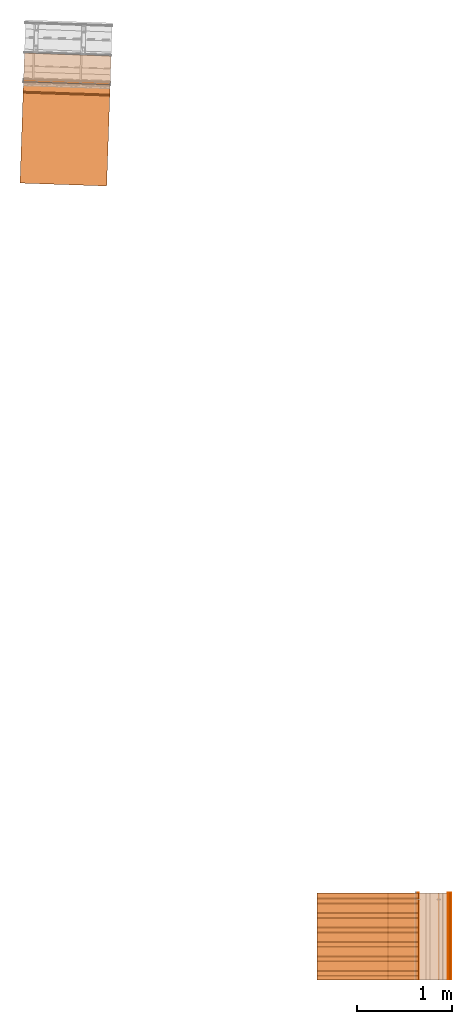
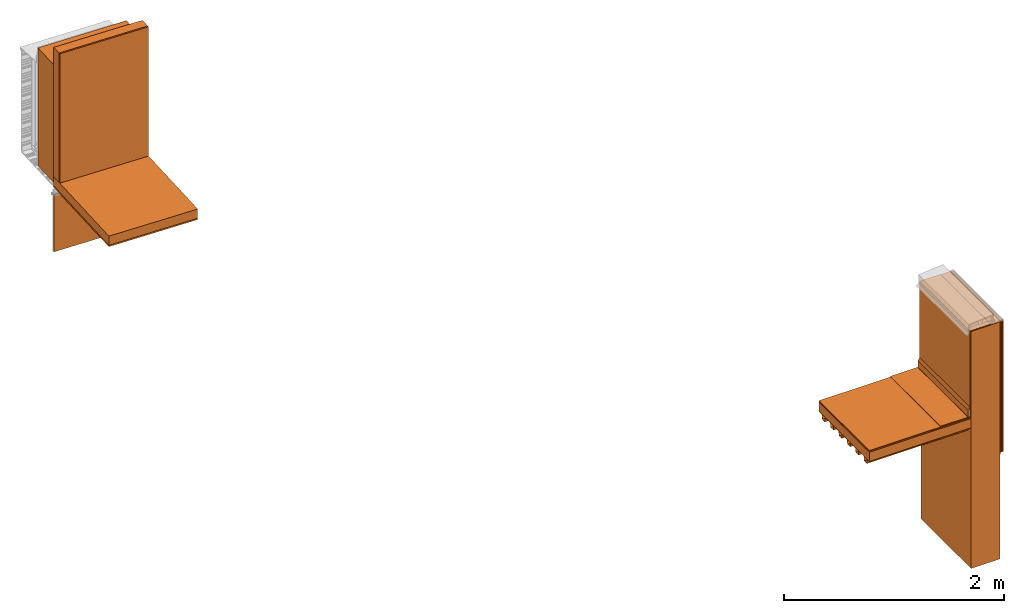
# One storey, part 1 of 7: 19 proxies.
"""IFC2X3 building model written with IfcOpenShell, lengths in feet."""

from ifc_helpers import new_model, entity, si_unit, converted_unit, derived_unit, direction, frame, frame_2d, origin, origin_2d_with_axis, place, context, subcontext, project, spatial, polyline, circle_curve, parameter, trimmed, segment, composite_curve, rectangle, outline, extrude, source, transform, mapped, material, type_object, type_shapes, element, save


model = new_model("IFC2X3")

# Units and contexts
model_context = context("Model", 3, precision=0.0001, world=origin(), true_north=direction((6.12303176911189e-17, 1.0)))
context_of_model = context(None, 3, precision=0.0001, world=origin(), true_north=direction((6.12303176911189e-17, 1.0)))
body_context = subcontext(model_context, "Body", "Model", "MODEL_VIEW")
ifc_project = project(units=[converted_unit("LENGTHUNIT", "FOOT", entity("IfcRatioMeasure", 0.3048), si_unit("LENGTHUNIT", "METRE"), dimensions=[1, 0, 0, 0, 0, 0, 0]), converted_unit("AREAUNIT", "SQUARE FOOT", entity("IfcRatioMeasure", 0.09290304), si_unit("AREAUNIT", "SQUARE_METRE"), dimensions=[2, 0, 0, 0, 0, 0, 0]), converted_unit("VOLUMEUNIT", "CUBIC FOOT", entity("IfcRatioMeasure", 0.028316846592), si_unit("VOLUMEUNIT", "CUBIC_METRE"), dimensions=[3, 0, 0, 0, 0, 0, 0]), converted_unit("PLANEANGLEUNIT", "DEGREE", entity("IfcRatioMeasure", 0.0174532925199433), si_unit("PLANEANGLEUNIT", "RADIAN"), dimensions=[0, 0, 0, 0, 0, 0, 0]), si_unit("MASSUNIT", "GRAM", prefix="KILO"), derived_unit("MASSDENSITYUNIT", [(si_unit("MASSUNIT", "GRAM", prefix="KILO"), 1), (si_unit("LENGTHUNIT", "METRE"), -3)]), si_unit("TIMEUNIT", "SECOND"), si_unit("FREQUENCYUNIT", "HERTZ"), si_unit("THERMODYNAMICTEMPERATUREUNIT", "DEGREE_CELSIUS"), derived_unit("THERMALTRANSMITTANCEUNIT", [(si_unit("MASSUNIT", "GRAM", prefix="KILO"), 1), (si_unit("THERMODYNAMICTEMPERATUREUNIT", "KELVIN"), -1), (si_unit("TIMEUNIT", "SECOND"), -3)]), derived_unit("VOLUMETRICFLOWRATEUNIT", [(si_unit("LENGTHUNIT", "METRE"), 3), (si_unit("TIMEUNIT", "SECOND"), -1)]), si_unit("ELECTRICCURRENTUNIT", "AMPERE"), si_unit("ELECTRICVOLTAGEUNIT", "VOLT"), si_unit("POWERUNIT", "WATT"), si_unit("FORCEUNIT", "NEWTON"), si_unit("ILLUMINANCEUNIT", "LUX"), si_unit("LUMINOUSFLUXUNIT", "LUMEN"), si_unit("LUMINOUSINTENSITYUNIT", "CANDELA"), derived_unit("USERDEFINED", [(si_unit("MASSUNIT", "GRAM", prefix="KILO"), -1), (si_unit("LENGTHUNIT", "METRE"), -2), (si_unit("TIMEUNIT", "SECOND"), 3), (si_unit("LUMINOUSFLUXUNIT", "LUMEN"), 1)]), derived_unit("LINEARVELOCITYUNIT", [(si_unit("LENGTHUNIT", "METRE"), 1), (si_unit("TIMEUNIT", "SECOND"), -1)]), si_unit("PRESSUREUNIT", "PASCAL"), derived_unit("USERDEFINED", [(si_unit("LENGTHUNIT", "METRE"), -2), (si_unit("MASSUNIT", "GRAM", prefix="KILO"), 1), (si_unit("TIMEUNIT", "SECOND"), -2)])], contexts=[model_context, context_of_model])

# Site, building, storey
site_placement = place(None, origin())
site = spatial("IfcSite", under=ifc_project, at=site_placement, CompositionType="ELEMENT")
building_placement = place(site_placement, origin())
building = spatial("IfcBuilding", under=site, at=building_placement, CompositionType="ELEMENT")
storey_placement = place(building_placement, origin())
storey = spatial("IfcBuildingStorey", under=building, at=storey_placement, Name="Level 1", CompositionType="ELEMENT", Elevation=0.0)

# Proxies
ifc_material_1 = material()
building_element_proxy_type_1 = type_object("IfcBuildingElementProxyType", Name="Rigid insulation 002:Rigid insulation 002", PredefinedType="NOTDEFINED", material=ifc_material_1)
shared_shape_1 = source(origin(), body_context, "Body", "SweptSolid", [
    extrude(rectangle(XDim=3.50495130620078, YDim=2.99999999999999, at=frame_2d((0.0, 7.105427357601e-15), x_axis=(1.0, 0.0))), frame((121.624397761532, -80.1652000961286, 15.0), z_axis=(0.0, 0.0, 1.0), x_axis=(-1.0, 0.0, 0.0)), (0.0, 0.0, 1.0), 0.333333333333337),
])
type_shapes(building_element_proxy_type_1, [shared_shape_1])
proxy_1_placement = place(storey_placement, origin())
element("IfcBuildingElementProxy", 1, at=proxy_1_placement, inside=storey, type_object=building_element_proxy_type_1, material=ifc_material_1, context=body_context, shape_type="MappedRepresentation", body=[
    mapped(shared_shape_1, transform((0.0, 0.0, 0.0), scale=1.0)),
])
ifc_material_2 = material(Name="_EXISTING CAST-IN-PLACE CONCRETE")
building_element_proxy_type_2 = type_object("IfcBuildingElementProxyType", Name="Concrete wall 002:Concrete wall 002", PredefinedType="NOTDEFINED", material=ifc_material_2)
shared_shape_2 = source(origin(), body_context, "Body", "SweptSolid", [
    extrude(rectangle(XDim=0.999999999999972, YDim=2.99999999999999, at=frame_2d((1.4210854715202e-14, 7.105427357601e-15), x_axis=(1.0, 0.0))), frame((123.876873414633, -80.1652000961286, 9.875), z_axis=(0.0, 0.0, 1.0), x_axis=(-1.0, 0.0, 0.0)), (0.0, 0.0, 1.0), 8.625),
])
type_shapes(building_element_proxy_type_2, [shared_shape_2])
proxy_2_placement = place(storey_placement, origin())
element("IfcBuildingElementProxy", 2, at=proxy_2_placement, inside=storey, type_object=building_element_proxy_type_2, material=ifc_material_2, ObjectType="Concrete wall 002 : Concrete wall 002:Concrete wall 002", context=body_context, shape_type="MappedRepresentation", body=[
    mapped(shared_shape_2, transform((0.0, 0.0, 0.0), scale=1.0)),
])
ifc_material_3 = material(Name="TPO MEMBRANE ROOF MEMBRANE")
building_element_proxy_type_3 = type_object("IfcBuildingElementProxyType", Name="TPO Membrane 002:TPO Membrane 002", PredefinedType="NOTDEFINED", material=ifc_material_3)
shared_shape_3 = source(origin(), body_context, "Body", "SweptSolid", [
    extrude(outline(composite_curve([segment(polyline([(0.0658482143068539, -2.14143887680021), (0.784598214306726, -2.14143887680021)]), True, "CONTINUOUS"), segment(polyline([(0.784598214306726, -2.14143887680021), (0.784598214306726, -2.13102221013354)]), True, "CONTINUOUS"), segment(polyline([(0.784598214306726, -2.13102221013354), (0.0762648809735396, -2.13102221013354)]), True, "CONTINUOUS"), segment(polyline([(0.0762648809735396, -2.13102221013354), (0.0762648809435831, 0.630175331836318)]), True, "CONTINUOUS"), segment(polyline([(0.0762648809435831, 0.630175331836318), (0.0163690476108229, 0.733917958330316)]), True, "CONTINUOUS"), segment(polyline([(0.0163690476108229, 0.733917958330316), (0.0163690476108229, 0.959969644729439)]), True, "CONTINUOUS"), segment(trimmed(circle_curve(frame_2d((-0.00446428572251989, 0.959969644729439), x_axis=(1.0, 0.0)), 0.0208333333333333), [parameter(0.0)], [parameter(90.0000000000001)], True, "PARAMETER"), True, "CONTINUOUS"), segment(polyline([(-0.00446428572251989, 0.980802978062773), (-0.944568452389419, 0.980802978062776)]), True, "CONTINUOUS"), segment(polyline([(-0.944568452389419, 0.980802978062776), (-0.944568452389419, 0.97038631139611)]), True, "CONTINUOUS"), segment(polyline([(-0.944568452389419, 0.97038631139611), (-0.00446428572251989, 0.970386311396105)]), True, "CONTINUOUS"), segment(trimmed(circle_curve(frame_2d((-0.00446428572251989, 0.959969644729439), x_axis=(1.0, 0.0)), 0.0104166666666667), [parameter(0.0)], [parameter(90.0000000000001)], True, "PARAMETER"), False, "CONTINUOUS"), segment(polyline([(0.00595238094415151, 0.959969644729439), (0.00595238094415151, 0.731126820909159)]), True, "CONTINUOUS"), segment(polyline([(0.00595238094415151, 0.731126820909159), (0.0658482142769685, 0.627384194415056)]), True, "CONTINUOUS"), segment(polyline([(0.0658482142769685, 0.627384194415056), (0.0658482143068539, -2.14143887680021)]), True, "CONTINUOUS")], self_intersect=False)), frame((123.269358533659, -81.6652000961286, 16.3898111231998), z_axis=(0.0, 1.0, 0.0), x_axis=(1.0, 0.0, 0.0)), (0.0, 0.0, 1.0), 3.0),
])
type_shapes(building_element_proxy_type_3, [shared_shape_3])
proxy_3_placement = place(storey_placement, origin())
element("IfcBuildingElementProxy", 3, at=proxy_3_placement, inside=storey, type_object=building_element_proxy_type_3, material=ifc_material_3, ObjectType="TPO Membrane 002 : TPO Membrane 002:TPO Membrane 002", context=body_context, shape_type="MappedRepresentation", body=[
    mapped(shared_shape_3, transform((0.0, 0.0, 0.0), scale=1.0)),
])
ifc_material_4 = material()
building_element_proxy_type_4 = type_object("IfcBuildingElementProxyType", Name="Mortar bed 1:Mortar bed 002", PredefinedType="NOTDEFINED", material=ifc_material_4)
shared_shape_4 = source(origin(), body_context, "Body", "SweptSolid", [
    extrude(rectangle(XDim=3.0, YDim=0.0208333333333712, at=origin_2d_with_axis()), frame((123.366456747966, -80.1652000961286, 15.375), z_axis=(0.0, 0.0, 1.0), x_axis=(0.0, 1.0, 0.0)), (0.0, 0.0, 1.0), 3.125),
])
type_shapes(building_element_proxy_type_4, [shared_shape_4])
proxy_4_placement = place(storey_placement, origin())
element("IfcBuildingElementProxy", 4, at=proxy_4_placement, inside=storey, type_object=building_element_proxy_type_4, material=ifc_material_4, ObjectType="Mortar bed 002 : Mortar bed 1:Mortar bed 002", context=body_context, shape_type="MappedRepresentation", body=[
    mapped(shared_shape_4, transform((0.0, 0.0, 0.0), scale=1.0)),
])
ifc_material_5 = material(Name="PRESSURE TREATED WOOD BLOCKING - SIZE AS")
building_element_proxy_type_5 = type_object("IfcBuildingElementProxyType", Name="Concrete wall001", PredefinedType="NOTDEFINED", material=ifc_material_5)
shared_shape_5 = source(origin(), body_context, "Body", "SweptSolid", [
    extrude(rectangle(XDim=3.0, YDim=1.00000000008858, at=origin_2d_with_axis()), frame((111.232112399029, -50.1693051540586, 9.87499999999999), z_axis=(0.0, 0.0, 1.0), x_axis=(-0.999414947916633, 0.034201781836541, 0.0)), (0.0, 0.0, 1.0), 4.29166666666666),
])
type_shapes(building_element_proxy_type_5, [shared_shape_5])
proxy_5_placement = place(storey_placement, origin())
element("IfcBuildingElementProxy", 5, at=proxy_5_placement, inside=storey, type_object=building_element_proxy_type_5, material=ifc_material_5, Name="Concrete wall001:Concrete wall001", ObjectType="Concrete wall001", context=body_context, shape_type="MappedRepresentation", body=[
    mapped(shared_shape_5, transform((0.0, 0.0, 0.0), scale=1.0)),
])
ifc_material_6 = material(Name="Rigid insulation")
building_element_proxy_type_6 = type_object("IfcBuildingElementProxyType", Name="Insulation horizontal001", PredefinedType="NOTDEFINED", material=ifc_material_6)
shared_shape_6 = source(origin(), body_context, "Body", "SweptSolid", [
    extrude(rectangle(XDim=3.00000000000001, YDim=3.50495130610237, at=frame_2d((7.105427357601e-15, 2.22044604925031e-16), x_axis=(1.0, 0.0))), frame((111.15507371815, -52.4204629915805, 9.76041666666666), z_axis=(0.0, 0.0, 1.0), x_axis=(-0.999414947916632, 0.0342017818365576, 0.0)), (0.0, 0.0, 1.0), 0.333333333333334),
])
type_shapes(building_element_proxy_type_6, [shared_shape_6])
proxy_6_placement = place(storey_placement, origin())
element("IfcBuildingElementProxy", 6, at=proxy_6_placement, inside=storey, type_object=building_element_proxy_type_6, material=ifc_material_6, Name="Insulation horizontal001:Insulation horizontal001", ObjectType="Insulation horizontal001", context=body_context, shape_type="MappedRepresentation", body=[
    mapped(shared_shape_6, transform((0.0, 0.0, 0.0), scale=1.0)),
])
building_element_proxy_type_7 = type_object("IfcBuildingElementProxyType", Name="Insulation vertical001", PredefinedType="NOTDEFINED", material=ifc_material_6)
shared_shape_7 = source(origin(), body_context, "Body", "SweptSolid", [
    extrude(rectangle(XDim=2.99999999999999, YDim=0.333333333431769, at=frame_2d((7.105427357601e-15, 2.35922392732846e-16), x_axis=(1.0, 0.0))), frame((111.209311211139, -50.8355817859981, 10.09375), z_axis=(0.0, 0.0, 1.0), x_axis=(-0.999414947916632, 0.0342017818365767, 0.0)), (0.0, 0.0, 1.0), 4.7067749343832),
])
type_shapes(building_element_proxy_type_7, [shared_shape_7])
proxy_7_placement = place(storey_placement, origin())
element("IfcBuildingElementProxy", 7, at=proxy_7_placement, inside=storey, type_object=building_element_proxy_type_7, material=ifc_material_6, Name="Insulation vertical001:Insulation vertical001", ObjectType="Insulation vertical001", context=body_context, shape_type="MappedRepresentation", body=[
    mapped(shared_shape_7, transform((0.0, 0.0, 0.0), scale=1.0)),
])
building_element_proxy_type_8 = type_object("IfcBuildingElementProxyType", Name="Inner gypsum board001", PredefinedType="NOTDEFINED", material=ifc_material_5)
shared_shape_8 = source(origin(), body_context, "Body", "SweptSolid", [
    extrude(rectangle(XDim=3.00000000000001, YDim=0.0520833333333173, at=frame_2d((1.11022302462516e-16, -3.55097895532452e-15), x_axis=(1.0, 0.0))), frame((111.202720242762, -51.0281773749685, 10.09375), z_axis=(0.0, 0.0, 1.0), x_axis=(-0.999414947916637, 0.0342017818364297, 0.0)), (0.0, 0.0, 1.0), 4.7067749343832),
])
type_shapes(building_element_proxy_type_8, [shared_shape_8])
proxy_8_placement = place(storey_placement, origin())
element("IfcBuildingElementProxy", 8, at=proxy_8_placement, inside=storey, type_object=building_element_proxy_type_8, material=ifc_material_5, Name="Inner gypsum board001:Inner gypsum board001", ObjectType="Inner gypsum board001", context=body_context, shape_type="MappedRepresentation", body=[
    mapped(shared_shape_8, transform((0.0, 0.0, 0.0), scale=1.0)),
])
building_element_proxy_type_9 = type_object("IfcBuildingElementProxyType", Name="Inner ceiling001", PredefinedType="NOTDEFINED", material=ifc_material_5)
shared_shape_9 = source(origin(), body_context, "Body", "SweptSolid", [
    extrude(rectangle(XDim=3.0, YDim=3.50495130633201, at=frame_2d((7.105427357601e-15, 2.22044604925031e-16), x_axis=(1.0, 0.0))), frame((111.155073718154, -52.4204629914657, 9.70833333333332), z_axis=(0.0, 0.0, 1.0), x_axis=(-0.999414947916632, 0.0342017818365529, 0.0)), (0.0, 0.0, 1.0), 0.0520833333333339),
])
type_shapes(building_element_proxy_type_9, [shared_shape_9])
proxy_9_placement = place(storey_placement, origin())
element("IfcBuildingElementProxy", 9, at=proxy_9_placement, inside=storey, type_object=building_element_proxy_type_9, material=ifc_material_5, Name="Inner ceiling001:Inner ceiling001", ObjectType="Inner ceiling001", context=body_context, shape_type="MappedRepresentation", body=[
    mapped(shared_shape_9, transform((0.0, 0.0, 0.0), scale=1.0)),
])
ifc_material_7 = material(Name="Clear glass")
building_element_proxy_type_10 = type_object("IfcBuildingElementProxyType", Name="Glass panel 004", PredefinedType="NOTDEFINED", material=ifc_material_7)
shared_shape_10 = source(origin(), body_context, "Body", "SweptSolid", [
    extrude(rectangle(XDim=3.0, YDim=0.0156250000000211, at=origin_2d_with_axis()), frame((111.2150071805, -50.6691390856077, 7.3556443373819), z_axis=(0.0, 0.0, 1.0), x_axis=(-0.999414947916663, 0.0342017818356435, 0.0)), (0.0, 0.0, 1.0), 2.094323495),
])
type_shapes(building_element_proxy_type_10, [shared_shape_10])
proxy_10_placement = place(storey_placement, origin())
element("IfcBuildingElementProxy", 10, at=proxy_10_placement, inside=storey, type_object=building_element_proxy_type_10, material=ifc_material_7, Name="Glass panel 004:Glass panel 004", ObjectType="Glass panel 004", context=body_context, shape_type="MappedRepresentation", body=[
    mapped(shared_shape_10, transform((0.0, 0.0, 0.0), scale=1.0)),
])
ifc_material_8 = material()
building_element_proxy_type_11 = type_object("IfcBuildingElementProxyType", Name="Cement bond coat 002:Cement bond coat 002", PredefinedType="NOTDEFINED", material=ifc_material_8)
shared_shape_11 = source(origin(), body_context, "Body", "SweptSolid", [
    extrude(outline(polyline([(-2.88843881966443, 0.15882808898568), (-2.88843881966443, -0.648697504397737), (-2.88323048633111, -0.648697504397737), (-2.8832304863311, 0.153619755652366), (1.89789785805362, 0.153619755652366), (1.91489411546504, 0.165520663213195), (1.96051951366896, 0.165520663213195), (1.96051951366896, 0.170728996546524), (1.91325193427296, 0.170728996546524), (1.89625567686151, 0.158828088985681), (-2.88843881966443, 0.15882808898568)])), frame((124.223253658968, -81.6652000961286, 15.6271861803356), z_axis=(0.0, -1.0, 0.0), x_axis=(0.0, 0.0, -1.0)), (0.0, 0.0, -1.0), 3.0),
])
type_shapes(building_element_proxy_type_11, [shared_shape_11])
proxy_11_placement = place(storey_placement, origin())
element("IfcBuildingElementProxy", 11, at=proxy_11_placement, inside=storey, type_object=building_element_proxy_type_11, material=ifc_material_8, context=body_context, shape_type="MappedRepresentation", body=[
    mapped(shared_shape_11, transform((0.0, 0.0, 0.0), scale=1.0)),
])
ifc_material_9 = material()
building_element_proxy_type_12 = type_object("IfcBuildingElementProxyType", Name="Cement bond coat 002:Cement bond coat 002", PredefinedType="NOTDEFINED", material=ifc_material_9)
shared_shape_12 = source(origin(), body_context, "Body", "SweptSolid", [
    extrude(rectangle(XDim=3.0, YDim=0.0156250000000142, at=origin_2d_with_axis()), frame((124.473227581287, -80.1652000961286, 13.744164864019), z_axis=(0.0, 0.0, 1.0), x_axis=(0.0, 1.0, 0.0)), (0.0, 0.0, 1.0), 4.7714601359811),
])
type_shapes(building_element_proxy_type_12, [shared_shape_12])
proxy_12_placement = place(storey_placement, origin())
element("IfcBuildingElementProxy", 12, at=proxy_12_placement, inside=storey, type_object=building_element_proxy_type_12, material=ifc_material_9, context=body_context, shape_type="MappedRepresentation", body=[
    mapped(shared_shape_12, transform((0.0, 0.0, 0.0), scale=1.0)),
])
ifc_material_10 = material()
building_element_proxy_type_13 = type_object("IfcBuildingElementProxyType", Name="Cement bond coat 002:Cement bond coat 002", PredefinedType="NOTDEFINED", material=ifc_material_10)
shared_shape_13 = source(origin(), body_context, "Body", "SweptSolid", [
    extrude(rectangle(XDim=3.0, YDim=0.0196850393700743, at=frame_2d((0.0, -7.105427357601e-15), x_axis=(1.0, 0.0))), frame((124.490882600972, -80.1652000961286, 13.744164864019), z_axis=(0.0, 0.0, 1.0), x_axis=(0.0, 1.0, 0.0)), (0.0, 0.0, 1.0), 4.77146013598109),
])
type_shapes(building_element_proxy_type_13, [shared_shape_13])
proxy_13_placement = place(storey_placement, origin())
element("IfcBuildingElementProxy", 13, at=proxy_13_placement, inside=storey, type_object=building_element_proxy_type_13, material=ifc_material_10, context=body_context, shape_type="MappedRepresentation", body=[
    mapped(shared_shape_13, transform((0.0, 0.0, 0.0), scale=1.0)),
])
ifc_material_11 = material()
building_element_proxy_type_14 = type_object("IfcBuildingElementProxyType", Name="Cement bond coat 002:Cement bond coat 002", PredefinedType="NOTDEFINED", material=ifc_material_11)
shared_shape_14 = source(origin(), body_context, "Body", "SweptSolid", [
    extrude(rectangle(XDim=3.0, YDim=0.0416666666666714, at=frame_2d((0.0, -1.4210854715202e-14), x_axis=(1.0, 0.0))), frame((124.444581747953, -80.1652000961286, 13.744164864019), z_axis=(0.0, 0.0, 1.0), x_axis=(0.0, 1.0, 0.0)), (0.0, 0.0, 1.0), 4.77146013598109),
])
type_shapes(building_element_proxy_type_14, [shared_shape_14])
proxy_14_placement = place(storey_placement, origin())
element("IfcBuildingElementProxy", 14, at=proxy_14_placement, inside=storey, type_object=building_element_proxy_type_14, material=ifc_material_11, context=body_context, shape_type="MappedRepresentation", body=[
    mapped(shared_shape_14, transform((0.0, 0.0, 0.0), scale=1.0)),
])
ifc_material_12 = material(Name="SCRATCH COAT (MATCH MORTAR BED SPECS)")
building_element_proxy_type_15 = type_object("IfcBuildingElementProxyType", Name="Cement bond coat 002:Cement bond coat 002", PredefinedType="NOTDEFINED", material=ifc_material_12)
shared_shape_15 = source(origin(), body_context, "Body", "SweptSolid", [
    extrude(rectangle(XDim=3.0, YDim=0.0208333333333286, at=origin_2d_with_axis()), frame((124.413331747953, -80.1652000961286, 13.744164864019), z_axis=(0.0, 0.0, 1.0), x_axis=(0.0, 1.0, 0.0)), (0.0, 0.0, 1.0), 4.77146013598109),
])
type_shapes(building_element_proxy_type_15, [shared_shape_15])
proxy_15_placement = place(storey_placement, origin())
element("IfcBuildingElementProxy", 15, at=proxy_15_placement, inside=storey, type_object=building_element_proxy_type_15, material=ifc_material_12, context=body_context, shape_type="MappedRepresentation", body=[
    mapped(shared_shape_15, transform((0.0, 0.0, 0.0), scale=1.0)),
])
ifc_material_13 = material(Name="METAL LATH - (AT TILE MOVEMENT JOINTS)")
building_element_proxy_type_16 = type_object("IfcBuildingElementProxyType", Name="Cement bond coat 002:Cement bond coat 002", PredefinedType="NOTDEFINED", material=ifc_material_13)
shared_shape_16 = source(origin(), body_context, "Body", "SweptSolid", [
    extrude(rectangle(XDim=3.0, YDim=0.0208333333333286, at=origin_2d_with_axis()), frame((124.39249841462, -80.1652000961286, 13.744164864019), z_axis=(0.0, 0.0, 1.0), x_axis=(0.0, 1.0, 0.0)), (0.0, 0.0, 1.0), 4.77146013598109),
])
type_shapes(building_element_proxy_type_16, [shared_shape_16])
proxy_16_placement = place(storey_placement, origin())
element("IfcBuildingElementProxy", 16, at=proxy_16_placement, inside=storey, type_object=building_element_proxy_type_16, material=ifc_material_13, context=body_context, shape_type="MappedRepresentation", body=[
    mapped(shared_shape_16, transform((0.0, 0.0, 0.0), scale=1.0)),
])
ifc_material_14 = material(Name="EXISTING METAL DECK (REPAIR/AS)")
building_element_proxy_type_17 = type_object("IfcBuildingElementProxyType", Name="Generic Models 7", PredefinedType="NOTDEFINED", material=ifc_material_14)
shared_shape_17 = source(origin(), body_context, "Body", "SweptSolid", [
    extrude(outline(polyline([(-1.33022594872659, -0.0893429487164834), (-1.173794424901, -0.0893429487164834), (-1.14449754990103, 0.0669070512807881), (-0.859522823726564, 0.0669070512807881), (-0.830225948726593, -0.0893429487164834), (-0.673794424901004, -0.0893429487164834), (-0.644497549901033, 0.0669070512807881), (-0.359522823726564, 0.0669070512807881), (-0.330225948726593, -0.0893429487164834), (-0.173794424901004, -0.0893429487164834), (-0.144497549901033, 0.0669070512807899), (0.140477176273436, 0.0669070512807899), (0.169774051273407, -0.0893429487164816), (0.326205575098996, -0.0893429487164816), (0.355502450098967, 0.0669070512807917), (0.640477176273436, 0.0669070512807917), (0.669774051273407, -0.0893429487164799), (0.826205575098996, -0.0893429487164799), (0.855502450098967, 0.0669070512807934), (1.14047717627344, 0.0669070512807934), (1.16977405127341, -0.0893429487164781), (1.326205575099, -0.0893429487164781), (1.35550245009897, 0.066907051280797), (1.52412224176565, 0.066907051280797), (1.52412224176565, 0.0773237179474631), (1.34685738460674, 0.0773237179474631), (1.31756050960676, -0.078926282049812), (1.17841911676564, -0.078926282049812), (1.14912224176567, 0.0773237179474595), (0.846857384606736, 0.0773237179474595), (0.817560509606764, -0.0789262820498138), (0.678419116765639, -0.0789262820498138), (0.649122241765667, 0.0773237179474577), (0.346857384606736, 0.0773237179474577), (0.317560509606764, -0.0789262820498156), (0.178419116765639, -0.0789262820498156), (0.149122241765667, 0.077323717947456), (-0.153142615393264, 0.077323717947456), (-0.182439490393236, -0.0789262820498173), (-0.321580883234361, -0.0789262820498173), (-0.350877758234333, 0.0773237179474542), (-0.653142615393264, 0.0773237179474542), (-0.682439490393236, -0.0789262820498173), (-0.821580883234361, -0.0789262820498173), (-0.850877758234333, 0.0773237179474542), (-1.15314261539326, 0.0773237179474542), (-1.18243949039324, -0.0789262820498173), (-1.32158088323436, -0.0789262820498173), (-1.35087775823433, 0.0773237179474542), (-1.47587775823433, 0.0773237179474542), (-1.47587775823433, 0.0669070512807881), (-1.35952282372656, 0.0669070512807881), (-1.33022594872659, -0.0893429487164834)])), frame((119.871922108432, -80.1893223378943, 14.9226762820525), z_axis=(1.0, 0.0, 0.0), x_axis=(0.0, 1.0, 0.0)), (0.0, 0.0, 1.0), 3.50495130618845),
])
type_shapes(building_element_proxy_type_17, [shared_shape_17])
proxy_17_placement = place(storey_placement, origin())
element("IfcBuildingElementProxy", 17, at=proxy_17_placement, inside=storey, type_object=building_element_proxy_type_17, material=ifc_material_14, Name="Generic Models 7:Generic Models 7", ObjectType="Generic Models 7", context=body_context, shape_type="MappedRepresentation", body=[
    mapped(shared_shape_17, transform((0.0, 0.0, 0.0), scale=1.0)),
])
ifc_material_15 = material(Name="EXISTING COVER BOARD (REPAIR/AS)")
building_element_proxy_type_18 = type_object("IfcBuildingElementProxyType", Name="Cement bond coat 002:Cement bond coat 002", PredefinedType="NOTDEFINED", material=ifc_material_15)
shared_shape_18 = source(origin(), body_context, "Body", "SweptSolid", [
    extrude(rectangle(XDim=3.0, YDim=3.50495130620079, at=frame_2d((-7.105427357601e-15, 0.0), x_axis=(1.0, 0.0))), frame((121.624397761532, -80.1652000961286, 15.3333333333333), z_axis=(0.0, 0.0, 1.0), x_axis=(0.0, 1.0, 0.0)), (0.0, 0.0, 1.0), 0.0416666666666661),
])
type_shapes(building_element_proxy_type_18, [shared_shape_18])
proxy_18_placement = place(storey_placement, origin())
element("IfcBuildingElementProxy", 18, at=proxy_18_placement, inside=storey, type_object=building_element_proxy_type_18, material=ifc_material_15, context=body_context, shape_type="MappedRepresentation", body=[
    mapped(shared_shape_18, transform((0.0, 0.0, 0.0), scale=1.0)),
])
building_element_proxy_type_19 = type_object("IfcBuildingElementProxyType", Name="TPO Membrane 002:TPO Membrane 002", PredefinedType="NOTDEFINED", material=ifc_material_3)
shared_shape_19 = source(origin(), body_context, "Body", "SweptSolid", [
    extrude(outline(composite_curve([segment(polyline([(-0.0892871589413335, -2.59746347962614), (-0.0788704922746675, -2.59746347962614)]), True, "CONTINUOUS"), segment(polyline([(-0.0788704922746675, -2.59746347962614), (-0.0788704922746675, 0.855404493207629)]), True, "CONTINUOUS"), segment(trimmed(circle_curve(frame_2d((-0.0684538256080014, 0.855404493207629), x_axis=(0.0, 1.0)), 0.0104166666666667), [parameter(6.15551830831724e-10)], [parameter(90.0000000000001)], True, "PARAMETER"), False, "CONTINUOUS"), segment(polyline([(-0.0684538256081133, 0.865821159874301), (0.236611476824171, 0.865821159877584)]), True, "CONTINUOUS"), segment(polyline([(0.236611476824171, 0.865821159877584), (0.236611476824171, 0.876237826544227)]), True, "CONTINUOUS"), segment(polyline([(0.236611476824171, 0.876237826544227), (-0.068453825608227, 0.876237826540915)]), True, "CONTINUOUS"), segment(trimmed(circle_curve(frame_2d((-0.0684538256080014, 0.855404493207629), x_axis=(0.0, 1.0)), 0.0208333333333333), [parameter(6.20437162822452e-10)], [parameter(90.0000000000001)], True, "PARAMETER"), True, "CONTINUOUS"), segment(polyline([(-0.0892871589413353, 0.855404493207629), (-0.0892871589413335, -2.59746347962614)]), True, "CONTINUOUS")], self_intersect=False)), frame((122.469385588079, -81.6652000961286, 15.4723751039753), z_axis=(0.0, 1.0, 0.0), x_axis=(0.0, 0.0, 1.0)), (0.0, 0.0, 1.0), 3.0),
])
type_shapes(building_element_proxy_type_19, [shared_shape_19])
proxy_19_placement = place(storey_placement, origin())
element("IfcBuildingElementProxy", 19, at=proxy_19_placement, inside=storey, type_object=building_element_proxy_type_19, material=ifc_material_3, ObjectType="TPO Membrane 002:1 : TPO Membrane 002:TPO Membrane 002", context=body_context, shape_type="MappedRepresentation", body=[
    mapped(shared_shape_19, transform((0.0, 0.0, 0.0), scale=1.0)),
])

save(model, "model.ifc")
